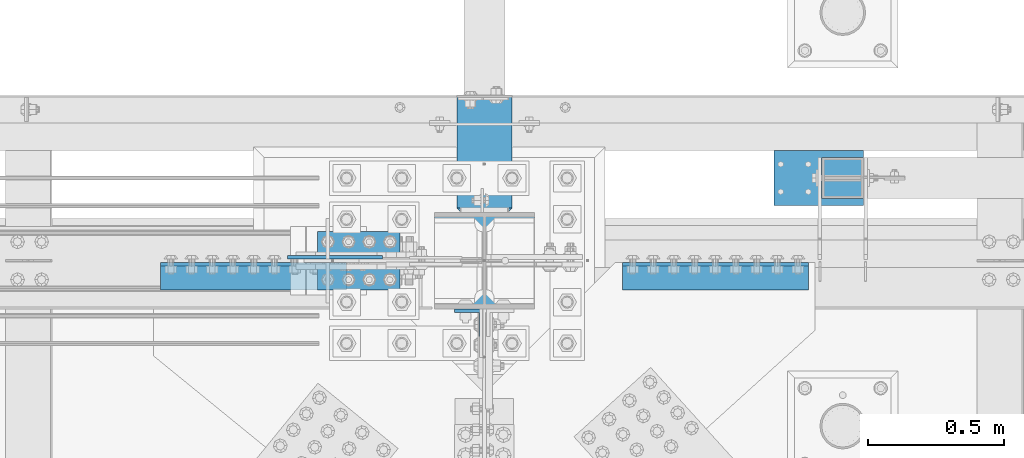
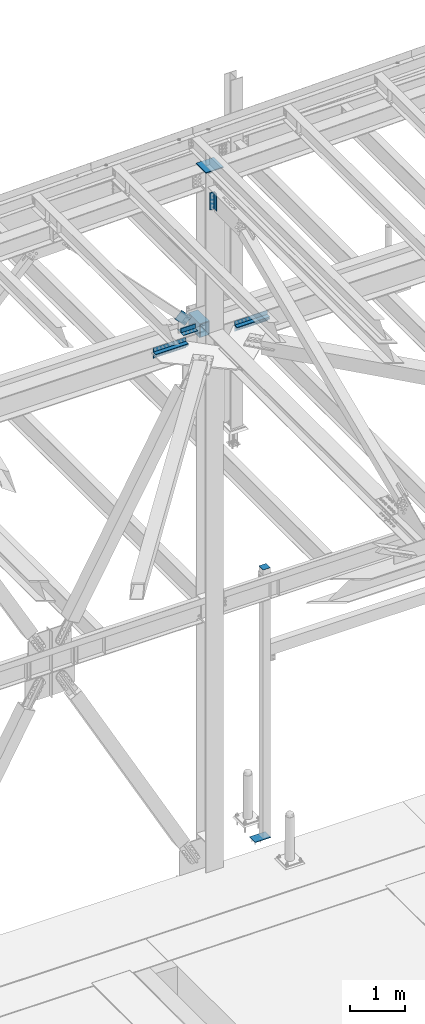
# One storey, part 2541 of 3843: 11 beams, 1 member, 8 elements without a shape of their own.
"""IFC2X3 building model written with IfcOpenShell, lengths in millimetres."""

from ifc_helpers import new_model, si_unit, frame, origin_with_axes, place, context, subcontext, project, spatial, faceted_brep, material, type_object, element, aggregate, save


model = new_model("IFC2X3")

# Units and contexts
model_context = context("Model", 3, precision=1e-05, world=origin_with_axes())
body_context = subcontext(model_context, "Body", "Model", "MODEL_VIEW")
ifc_project = project(units=[si_unit("LENGTHUNIT", "METRE", prefix="MILLI"), si_unit("AREAUNIT", "SQUARE_METRE"), si_unit("VOLUMEUNIT", "CUBIC_METRE"), si_unit("MASSUNIT", "GRAM", prefix="KILO"), si_unit("TIMEUNIT", "SECOND"), si_unit("PLANEANGLEUNIT", "RADIAN"), si_unit("SOLIDANGLEUNIT", "STERADIAN"), si_unit("THERMODYNAMICTEMPERATUREUNIT", "DEGREE_CELSIUS"), si_unit("LUMINOUSINTENSITYUNIT", "LUMEN")], contexts=[model_context])

# Site, building, storey
site_placement = place(None, origin_with_axes())
site = spatial("IfcSite", under=ifc_project, at=site_placement, CompositionType="ELEMENT")
building_placement = place(site_placement, origin_with_axes())
building = spatial("IfcBuilding", under=site, at=building_placement, Name="Undefined", CompositionType="ELEMENT")
storey_placement = place(building_placement, origin_with_axes())
storey = spatial("IfcBuildingStorey", under=building, at=storey_placement, Name="Undefined", CompositionType="ELEMENT", Elevation=0.0)

# Assembly, beam
assembly_1_placement = place(storey_placement, origin_with_axes())
assembly_1 = element("IfcElementAssembly", 1, at=assembly_1_placement, inside=storey, Name="ANGLE", AssemblyPlace="NOTDEFINED", PredefinedType="RIGID_FRAME")
ifc_material_1 = material(Name="STEEL/A572-50")
beam_type_1 = type_object("IfcBeamType", Name="L4X4X3/8", PredefinedType="NOTDEFINED")
beam_1_placement = place(assembly_1_placement, frame((62326.0437500057, 92271.8499998305, 42519.6000000061), z_axis=(0.0, 0.0, 1.0), x_axis=(-1.0, 0.0, 0.0)))
beam_1 = element("IfcBeam", 2, at=beam_1_placement, type_object=beam_type_1, material=ifc_material_1, Name="ANGLE", ObjectType="L4X4X3/8", context=body_context, shape_type="Brep", body=[
    faceted_brep([(0.0, 50.8000000000029, -50.8000000000029), (0.0, 50.8000000000029, 50.8000000000029), (304.800000000003, 50.8000000000029, 50.8000000000029), (304.800000000003, 50.8000000000029, -50.8000000000029), (0.0, 41.2750000000015, 50.8000000000029), (304.800000000003, 41.2749999999942, 50.8000000000029), (0.0, 41.2749999999942, -41.2750000000015), (304.800000000003, 41.2749999999942, -41.2750000000015), (0.0, -50.8000000000029, -41.2750000000015), (304.800000000003, -50.8000000000029, -41.2750000000015), (0.0, -50.8000000000029, -50.8000000000029), (304.800000000003, -50.8000000000029, -50.8000000000029)], [[[0, 1, 2, 3]], [[1, 4, 5, 2]], [[4, 6, 7, 5]], [[6, 8, 9, 7]], [[8, 10, 11, 9]], [[10, 0, 3, 11]], [[5, 7, 9, 11, 3, 2]], [[10, 8, 6, 4, 1, 0]]]),
])
aggregate(assembly_1, [beam_1])

assembly_2_placement = place(storey_placement, origin_with_axes())
assembly_2 = element("IfcElementAssembly", 3, at=assembly_2_placement, inside=storey, Name="ANGLE", AssemblyPlace="NOTDEFINED", PredefinedType="RIGID_FRAME")
beam_2_placement = place(assembly_2_placement, frame((62021.2437500057, 92157.5499998305, 42519.6000000061), z_axis=(0.0, 0.0, 1.0), x_axis=(1.0, 0.0, 0.0)))
beam_2 = element("IfcBeam", 4, at=beam_2_placement, type_object=beam_type_1, material=ifc_material_1, Name="ANGLE", ObjectType="L4X4X3/8", context=body_context, shape_type="Brep", body=[
    faceted_brep([(0.0, 50.8000000000029, -50.8000000000029), (0.0, 50.8000000000029, 50.8000000000029), (304.800000000003, 50.8000000000029, 50.8000000000029), (304.800000000003, 50.8000000000029, -50.8000000000029), (0.0, 41.2750000000015, 50.8000000000029), (304.800000000003, 41.2749999999942, 50.8000000000029), (0.0, 41.2749999999942, -41.2750000000015), (304.800000000003, 41.2749999999942, -41.2750000000015), (0.0, -50.8000000000029, -41.2750000000015), (304.800000000003, -50.8000000000029, -41.2750000000015), (0.0, -50.8000000000029, -50.8000000000029), (304.800000000003, -50.8000000000029, -50.8000000000029)], [[[0, 1, 2, 3]], [[1, 4, 5, 2]], [[4, 6, 7, 5]], [[6, 8, 9, 7]], [[8, 10, 11, 9]], [[10, 0, 3, 11]], [[5, 7, 9, 11, 3, 2]], [[10, 8, 6, 4, 1, 0]]]),
])
aggregate(assembly_2, [beam_2])

# Assembly, beams
assembly_3_placement = place(storey_placement, origin_with_axes())
assembly_3 = element("IfcElementAssembly", 5, at=assembly_3_placement, inside=storey, Name="PLATE", AssemblyPlace="NOTDEFINED", PredefinedType="RIGID_FRAME")
beam_type_2 = type_object("IfcBeamType", Name="L4X4X1/2", PredefinedType="NOTDEFINED")
beam_3_placement = place(assembly_3_placement, frame((63830.199999016, 92157.5499999985, 42297.35), z_axis=(0.0, -1.0, 0.0), x_axis=(-1.0, 0.0, 0.0)))
beam_3 = element("IfcBeam", 6, at=beam_3_placement, type_object=beam_type_2, material=ifc_material_1, Name="ANGLE", ObjectType="L4X4X1/2", context=body_context, shape_type="Brep", body=[
    faceted_brep([(0.0, 50.8000000000029, -50.8000000000029), (0.0, 50.8000000000029, 50.8000000000029), (685.800000000003, 50.8000000000029, 50.8000000000029), (685.800000000003, 50.8000000000029, -50.8000000000029), (0.0, 38.0999999999985, 50.8000000000029), (685.800000000003, 38.0999999999985, 50.8000000000029), (0.0, 38.0999999999985, -38.0999999999985), (685.800000000003, 38.0999999999985, -38.1000000000058), (0.0, -50.8000000000029, -38.1000000000058), (685.800000000003, -50.8000000000029, -38.1000000000058), (0.0, -50.8000000000029, -50.8000000000029), (685.800000000003, -50.8000000000029, -50.8000000000029)], [[[0, 1, 2, 3]], [[1, 4, 5, 2]], [[4, 6, 7, 5]], [[6, 8, 9, 7]], [[8, 10, 11, 9]], [[10, 0, 3, 11]], [[5, 7, 9, 11, 3, 2]], [[10, 8, 6, 4, 1, 0]]]),
])
beam_4_placement = place(assembly_3_placement, frame((63144.399999016, 92157.5499999985, 42167.175), z_axis=(0.0, -1.0, 0.0), x_axis=(1.0, 0.0, 0.0)))
beam_4 = element("IfcBeam", 7, at=beam_4_placement, type_object=beam_type_2, material=ifc_material_1, Name="ANGLE", ObjectType="L4X4X1/2", context=body_context, shape_type="Brep", body=[
    faceted_brep([(0.0, 50.8000000000029, -50.8000000000029), (0.0, 50.8000000000029, 50.8000000000029), (685.800000000003, 50.8000000000029, 50.8000000000029), (685.800000000003, 50.8000000000029, -50.8000000000029), (0.0, 38.0999999999985, 50.8000000000029), (685.800000000003, 38.0999999999985, 50.8000000000029), (0.0, 38.0999999999985, -38.0999999999985), (685.800000000003, 38.0999999999985, -38.1000000000058), (0.0, -50.8000000000029, -38.1000000000058), (685.800000000003, -50.8000000000029, -38.1000000000058), (0.0, -50.8000000000029, -50.8000000000029), (685.800000000003, -50.8000000000029, -50.8000000000029)], [[[0, 1, 2, 3]], [[1, 4, 5, 2]], [[4, 6, 7, 5]], [[6, 8, 9, 7]], [[8, 10, 11, 9]], [[10, 0, 3, 11]], [[5, 7, 9, 11, 3, 2]], [[10, 8, 6, 4, 1, 0]]]),
])
aggregate(assembly_3, [beam_3, beam_4])

assembly_4_placement = place(storey_placement, origin_with_axes())
assembly_4 = element("IfcElementAssembly", 8, at=assembly_4_placement, inside=storey, Name="PLATE", AssemblyPlace="NOTDEFINED", PredefinedType="RIGID_FRAME")
beam_5_placement = place(assembly_4_placement, frame((62128.399999016, 92157.5500000197, 42297.35), z_axis=(0.0, -1.0, 0.0), x_axis=(-1.0, 0.0, 0.0)))
beam_5 = element("IfcBeam", 9, at=beam_5_placement, type_object=beam_type_2, material=ifc_material_1, Name="ANGLE", ObjectType="L4X4X1/2", context=body_context, shape_type="Brep", body=[
    faceted_brep([(0.0, 50.8000000000029, -50.8000000000029), (0.0, 50.8000000000029, 50.8000000000029), (685.800000000003, 50.8000000000029, 50.8000000000029), (685.800000000003, 50.8000000000029, -50.8000000000029), (0.0, 38.0999999999985, 50.8000000000029), (685.800000000003, 38.0999999999985, 50.8000000000029), (0.0, 38.0999999999985, -38.0999999999985), (685.800000000003, 38.0999999999985, -38.1000000000058), (0.0, -50.8000000000029, -38.1000000000058), (685.800000000003, -50.8000000000029, -38.1000000000058), (0.0, -50.8000000000029, -50.8000000000029), (685.800000000003, -50.8000000000029, -50.8000000000029)], [[[0, 1, 2, 3]], [[1, 4, 5, 2]], [[4, 6, 7, 5]], [[6, 8, 9, 7]], [[8, 10, 11, 9]], [[10, 0, 3, 11]], [[5, 7, 9, 11, 3, 2]], [[10, 8, 6, 4, 1, 0]]]),
])
beam_6_placement = place(assembly_4_placement, frame((61442.5999990159, 92157.5500000197, 42167.175), z_axis=(0.0, -1.0, 0.0), x_axis=(1.0, 0.0, 0.0)))
beam_6 = element("IfcBeam", 10, at=beam_6_placement, type_object=beam_type_2, material=ifc_material_1, Name="ANGLE", ObjectType="L4X4X1/2", context=body_context, shape_type="Brep", body=[
    faceted_brep([(0.0, 50.8000000000029, -50.8000000000029), (0.0, 50.8000000000029, 50.8000000000029), (685.800000000003, 50.8000000000029, 50.8000000000029), (685.800000000003, 50.8000000000029, -50.8000000000029), (0.0, 38.0999999999985, 50.8000000000029), (685.800000000003, 38.0999999999985, 50.8000000000029), (0.0, 38.0999999999985, -38.0999999999985), (685.800000000003, 38.0999999999985, -38.1000000000058), (0.0, -50.8000000000029, -38.1000000000058), (685.800000000003, -50.8000000000029, -38.1000000000058), (0.0, -50.8000000000029, -50.8000000000029), (685.800000000003, -50.8000000000029, -50.8000000000029)], [[[0, 1, 2, 3]], [[1, 4, 5, 2]], [[4, 6, 7, 5]], [[6, 8, 9, 7]], [[8, 10, 11, 9]], [[10, 0, 3, 11]], [[5, 7, 9, 11, 3, 2]], [[10, 8, 6, 4, 1, 0]]]),
])
aggregate(assembly_4, [beam_5, beam_6])

# Assembly, beam
assembly_5_placement = place(storey_placement, origin_with_axes())
assembly_5 = element("IfcElementAssembly", 11, at=assembly_5_placement, inside=storey, Name="PLATE", AssemblyPlace="NOTDEFINED", PredefinedType="RIGID_FRAME")
beam_7_placement = place(assembly_5_placement, frame((62577.6625, 91986.0999999771, 45498.0705578587), z_axis=(0.0, -1.0, 0.0), x_axis=(0.0, 0.0, -1.0)))
beam_7 = element("IfcBeam", 12, at=beam_7_placement, type_object=beam_type_2, material=ifc_material_1, Name="ANGLE", ObjectType="L4X4X1/2", context=body_context, shape_type="Brep", body=[
    faceted_brep([(0.0, 50.8000000000029, -50.8000000000029), (0.0, 50.8000000000029, 50.8000000000029), (381.0, 50.8000000000029, 50.8000000000029), (381.0, 50.8000000000029, -50.8000000000029), (0.0, 38.0999999999985, 50.8000000000029), (381.0, 38.0999999999985, 50.8000000000029), (0.0, 38.0999999999985, -38.0999999999985), (381.0, 38.0999999999985, -38.1000000000058), (0.0, -50.8000000000029, -38.1000000000058), (381.0, -50.8000000000029, -38.1000000000058), (0.0, -50.8000000000029, -50.8000000000029), (381.0, -50.8000000000029, -50.8000000000029)], [[[0, 1, 2, 3]], [[1, 4, 5, 2]], [[4, 6, 7, 5]], [[6, 8, 9, 7]], [[8, 10, 11, 9]], [[10, 0, 3, 11]], [[5, 7, 9, 11, 3, 2]], [[10, 8, 6, 4, 1, 0]]]),
])
aggregate(assembly_5, [beam_7])

# Assembly, member
assembly_6_placement = place(storey_placement, origin_with_axes())
assembly_6 = element("IfcElementAssembly", 13, at=assembly_6_placement, inside=storey, AssemblyPlace="NOTDEFINED", PredefinedType="RIGID_FRAME")
member_type = type_object("IfcMemberType", PredefinedType="NOTDEFINED")
member_placement = place(assembly_6_placement, frame((62186.4610729541, 92227.3999998305, 42666.1512815069), z_axis=(-0.721481345122377, 0.0, -0.692433873117431), x_axis=(-0.69243387311743, 0.0, 0.721481345122377)))
member = element("IfcMember", 14, at=member_placement, type_object=member_type, material=ifc_material_1, Name="PLATE", context=body_context, shape_type="Brep", body=[
    faceted_brep([(1.74622982740402e-10, 6.35000000000582, -101.600000000195), (-1.67347025126219e-10, 6.35000000000582, 101.600000000151), (292.1000000028, 6.35000000000582, 101.600000000661), (292.100000003156, 6.35000000000582, -101.599999999686), (-1.67347025126219e-10, -6.35000000000582, 101.600000000151), (292.1000000028, -6.35000000000582, 101.600000000661), (1.74622982740402e-10, -6.35000000000582, -101.600000000195), (292.100000003156, -6.35000000000582, -101.599999999686)], [[[0, 1, 2, 3]], [[1, 4, 5, 2]], [[4, 6, 7, 5]], [[6, 0, 3, 7]], [[5, 7, 3, 2]], [[6, 4, 1, 0]]]),
])
aggregate(assembly_6, [member])

# Assembly, beam
assembly_7_placement = place(storey_placement, origin_with_axes())
assembly_7 = element("IfcElementAssembly", 15, at=assembly_7_placement, inside=storey, Name="POST", AssemblyPlace="NOTDEFINED", PredefinedType="RIGID_FRAME")
beam_type_3 = type_object("IfcBeamType", PredefinedType="NOTDEFINED")
beam_8_placement = place(assembly_7_placement, frame((63957.2, 92443.3, 36433.125), z_axis=(1.0, 0.0, 0.0), x_axis=(0.0, 1.0, 0.0)))
beam_8 = element("IfcBeam", 16, at=beam_8_placement, type_object=beam_type_3, material=ifc_material_1, Name="PLATE", context=body_context, shape_type="Brep", body=[
    faceted_brep([(0.0, 3.17500000000291, -76.2000000000007), (0.0, 3.17499999999927, 76.1999969482422), (152.399999999994, 3.17500000000291, 76.1999999999971), (152.399999999994, 3.17500000000291, -76.1999999999971), (0.0, -3.17499999999927, 76.1999969482422), (152.399999999994, -3.17500000000291, 76.1999999999971), (0.0, -3.17500000000291, -76.2000000000007), (152.399999999994, -3.17500000000291, -76.1999999999971)], [[[0, 1, 2, 3]], [[1, 4, 5, 2]], [[4, 6, 7, 5]], [[6, 0, 3, 7]], [[5, 7, 3, 2]], [[6, 4, 1, 0]]]),
])

assembly_8_placement = place(storey_placement, origin_with_axes())
assembly_8 = element("IfcElementAssembly", 17, at=assembly_8_placement, inside=storey, Name="COLUMN", AssemblyPlace="NOTDEFINED", PredefinedType="RIGID_FRAME")
ifc_material_2 = material()
beam_type_4 = type_object("IfcBeamType", Name="HSS12X8X3/8", PredefinedType="NOTDEFINED")
beam_9_placement = place(assembly_8_placement, frame((62636.4, 92392.5, 42214.8), z_axis=(0.0, 0.0, 1.0), x_axis=(0.0, 1.0, 0.0)))
beam_9 = element("IfcBeam", 18, at=beam_9_placement, type_object=beam_type_4, material=ifc_material_2, Name="GIRT", ObjectType="HSS12X8X3/8", context=body_context, shape_type="Brep", body=[
    faceted_brep([(15.8750001309381, 101.600000000006, 152.399999999972), (15.8749984899478, 101.600000000006, -152.400000000031), (6.35000000002037, 92.0749999999971, -142.875), (6.35000000002037, 92.0749999999971, 142.875), (15.8749984899478, -101.600000000006, -152.400000000031), (6.35000000002037, -92.0749999999971, -142.875), (15.8750001044536, -101.600000052975, 152.399999973481), (6.35000000002037, -92.0749999999971, 142.875), (425.449999999983, -101.600000000006, 152.400000000001), (425.449999999983, 101.600000000006, 152.400000000001), (425.449999999983, -101.600000000006, -152.400000000001), (425.449999999983, 101.600000000006, -152.400000000001), (425.449999999957, -92.074999999968, 142.874999999971), (425.450000000015, 92.0749999999971, 142.875), (425.450000000015, 92.0749999999971, -142.875), (425.450000000015, -92.0749999999971, -142.875)], [[[0, 1, 2, 3]], [[4, 5, 2, 1]], [[6, 7, 5, 4]], [[8, 9, 0, 6]], [[10, 8, 6, 4]], [[11, 10, 4, 1]], [[9, 11, 1, 0]], [[8, 10, 11, 9], [12, 13, 14, 15]], [[3, 2, 14, 13]], [[2, 5, 15, 14]], [[5, 7, 12, 15]], [[7, 3, 13, 12]], [[0, 3, 7, 6]]]),
])

# Beam
beam_type_5 = type_object("IfcBeamType", PredefinedType="NOTDEFINED")
beam_10_placement = place(assembly_7_placement, frame((63868.2999984741, 92417.9000003815, 30486.35), z_axis=(-1.0, 0.0, 0.0), x_axis=(0.0, 1.0, 0.0)))
beam_10 = element("IfcBeam", 19, at=beam_10_placement, type_object=beam_type_5, material=ifc_material_1, context=body_context, shape_type="Brep", body=[
    faceted_brep([(-4.07453626394272e-10, 6.34999999999854, -165.099999999366), (3.92901711165905e-10, 6.34999999999854, 165.099999999351), (203.199999237055, 6.34999999999854, 165.099999999999), (203.199999237055, 6.34999999999854, -165.099999999999), (3.92901711165905e-10, -6.34999999999854, 165.099999999351), (203.199999237055, -6.34999999999854, 165.099999999999), (-4.07453626394272e-10, -6.34999999999854, -165.099999999366), (203.199999237055, -6.34999999999854, -165.099999999999)], [[[0, 1, 2, 3]], [[1, 4, 5, 2]], [[4, 6, 7, 5]], [[6, 0, 3, 7]], [[5, 7, 3, 2]], [[6, 4, 1, 0]]]),
])

aggregate(assembly_7, [beam_8, beam_10])

beam_type_6 = type_object("IfcBeamType", PredefinedType="NOTDEFINED")
beam_11_placement = place(assembly_8_placement, frame((62636.4, 92036.9, 45958.4593867864), z_axis=(1.0, 0.0, 0.0), x_axis=(0.0, 1.0, 0.0)))
beam_11 = element("IfcBeam", 20, at=beam_11_placement, type_object=beam_type_6, material=ifc_material_1, Name="PLATE", context=body_context, shape_type="Brep", body=[
    faceted_brep([(0.0, 9.52500000000146, -184.150000000001), (0.0, 9.52500000000146, 184.150000000001), (355.600000000006, 9.52500000000146, 184.150000000001), (355.600000000006, 9.52500000000146, -184.150000000001), (0.0, -9.52500000000146, 184.150000000001), (355.600000000006, -9.52500000000146, 184.150000000001), (0.0, -9.52500000000146, -184.150000000001), (355.600000000006, -9.52500000000146, -184.150000000001)], [[[0, 1, 2, 3]], [[1, 4, 5, 2]], [[4, 6, 7, 5]], [[6, 0, 3, 7]], [[5, 7, 3, 2]], [[6, 4, 1, 0]]]),
])

aggregate(assembly_8, [beam_11, beam_9])

save(model, "model.ifc")
